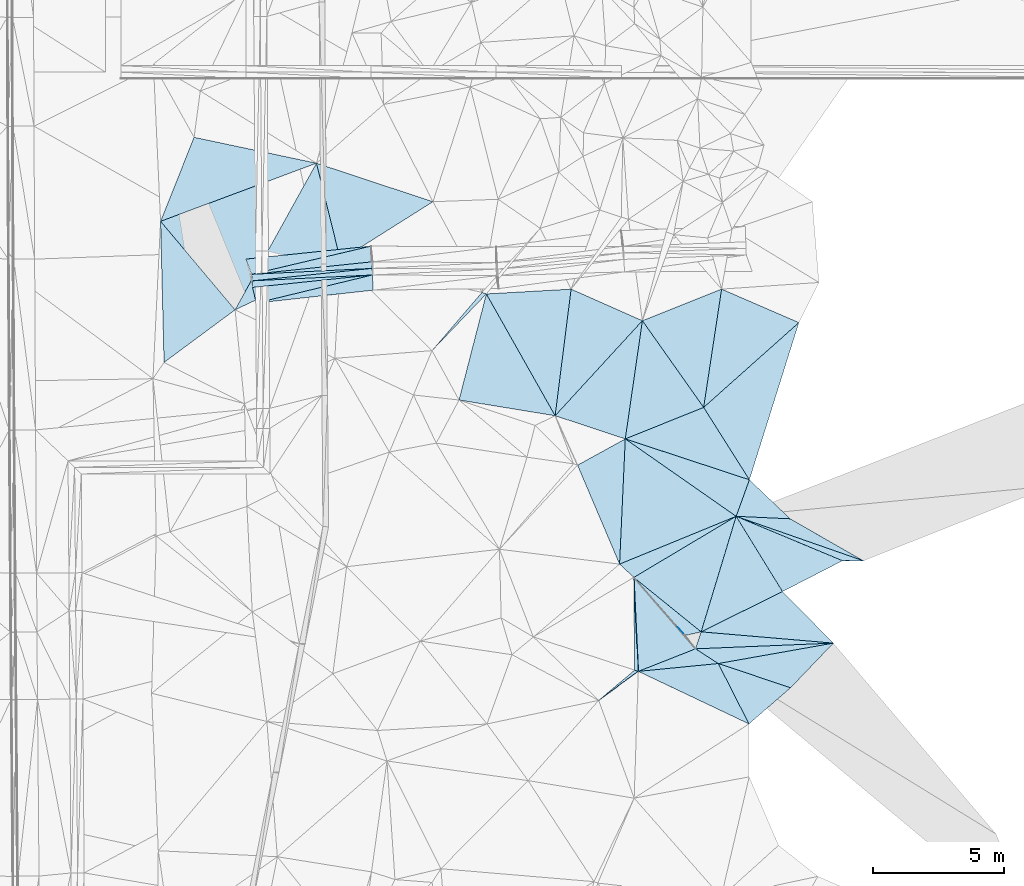
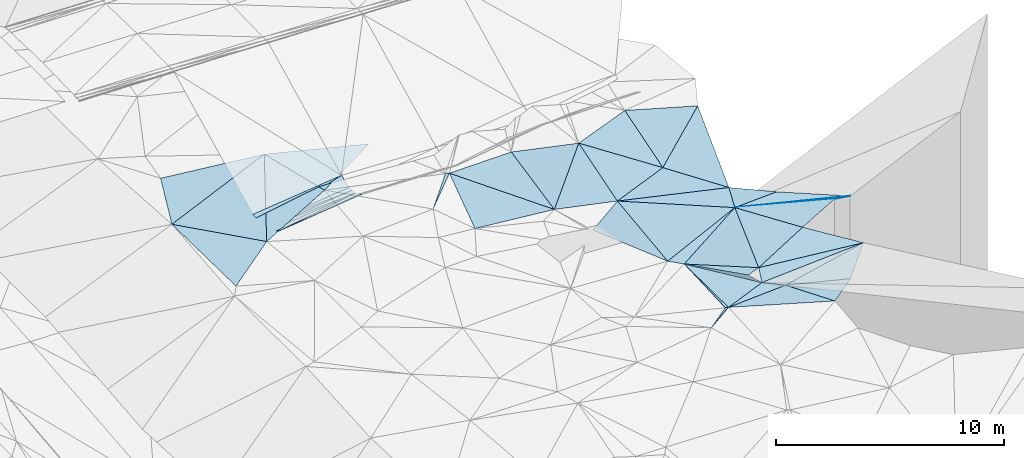
# One storey, part 100 of 275: 45 plates.
"""IFC2X3 building model written with IfcOpenShell, lengths in millimetres."""

from ifc_helpers import new_model, si_unit, frame, origin_with_axes, place, context, subcontext, project, spatial, polyline, outline, extrude, material, type_object, element, save


model = new_model("IFC2X3")

# Units and contexts
model_context = context("Model", 3, precision=1e-05, world=origin_with_axes())
body_context = subcontext(model_context, "Body", "Model", "MODEL_VIEW")
ifc_project = project(units=[si_unit("LENGTHUNIT", "METRE", prefix="MILLI"), si_unit("AREAUNIT", "SQUARE_METRE"), si_unit("VOLUMEUNIT", "CUBIC_METRE"), si_unit("MASSUNIT", "GRAM", prefix="KILO"), si_unit("TIMEUNIT", "SECOND"), si_unit("PLANEANGLEUNIT", "RADIAN"), si_unit("SOLIDANGLEUNIT", "STERADIAN"), si_unit("THERMODYNAMICTEMPERATUREUNIT", "DEGREE_CELSIUS"), si_unit("LUMINOUSINTENSITYUNIT", "LUMEN")], contexts=[model_context])

# Site, building, storey
site_placement = place(None, origin_with_axes())
site = spatial("IfcSite", under=ifc_project, at=site_placement, CompositionType="ELEMENT")
building_placement = place(site_placement, origin_with_axes())
building = spatial("IfcBuilding", under=site, at=building_placement, Name="Undefined", CompositionType="ELEMENT")
storey_placement = place(building_placement, origin_with_axes())
storey = spatial("IfcBuildingStorey", under=building, at=storey_placement, Name="Undefined", CompositionType="ELEMENT", Elevation=0.0)

# Plates
ifc_material = material()
plate_type_1 = type_object("IfcPlateType", PredefinedType="NOTDEFINED")
plate_1_placement = place(storey_placement, frame((-43648.8999455357, 52557.2817556051, 44878.2281642604), z_axis=(0.0255180972066615, 0.00110138363461027, -0.999673753616169), x_axis=(-0.99431762158297, -0.103355985983788, -0.0254952460451794)))
element("IfcPlate", 1, at=plate_1_placement, inside=storey, type_object=plate_type_1, material=ifc_material, Name="00_PR", context=body_context, shape_type="SweptSolid", body=[
    extrude(outline(polyline([(0.0, 0.0), (4599.837890625, -1.06265360955149e-08), (4584.71435546875, 250.000427246094), (0.0, 0.0)])), frame((-8.85201319254618e-08, 2.18876761149539e-07, -0.5000001331573), z_axis=(0.0, 0.0, 1.0), x_axis=(1.0, 0.0, 0.0)), (0.0, 0.0, 1.0), 1.0),
])
plate_2_placement = place(storey_placement, frame((-48233.3997002536, 52332.0848510419, 44760.9541646184), z_axis=(0.0255797537881398, -0.000154311443239196, -0.99967277265319), x_axis=(0.994319372064054, 0.103356003034222, 0.0254268160597377)))
element("IfcPlate", 2, at=plate_2_placement, inside=storey, type_object=plate_type_1, material=ifc_material, Name="00_PR", context=body_context, shape_type="SweptSolid", body=[
    extrude(outline(polyline([(0.0, 0.0), (4598.4130859375, -4.36557456851006e-09), (4584.71435546875, 250.000350952148), (0.0, 0.0)])), frame((-8.85201319254618e-08, 2.18876761149539e-07, -0.5000001331573), z_axis=(0.0, 0.0, 1.0), x_axis=(1.0, 0.0, 0.0)), (0.0, 0.0, 1.0), 1.0),
])
plate_3_placement = place(storey_placement, frame((-43661.1087510573, 52807.3598243362, 44877.877163002), z_axis=(0.0252905547313943, 0.00262884315740283, -0.999676686246625), x_axis=(-0.994319372064342, -0.103356003031297, -0.0254268160603611)))
element("IfcPlate", 3, at=plate_3_placement, inside=storey, type_object=plate_type_1, material=ifc_material, Name="00_PR", context=body_context, shape_type="SweptSolid", body=[
    extrude(outline(polyline([(0.0, 0.0), (4598.4130859375, -4.36557456851006e-09), (4598.41259765625, 249.999389648438), (0.0, 0.0)])), frame((-8.85201319254618e-08, 2.18876761149539e-07, -0.5000001331573), z_axis=(0.0, 0.0, 1.0), x_axis=(1.0, 0.0, 0.0)), (0.0, 0.0, 1.0), 1.0),
])
plate_4_placement = place(storey_placement, frame((-48259.246936965, 52580.7458929867, 44760.9541626138), z_axis=(0.0252901174471927, 0.00263770219602818, -0.999676673973456), x_axis=(0.994319372064054, 0.103356003034222, 0.0254268160597377)))
element("IfcPlate", 4, at=plate_4_placement, inside=storey, type_object=plate_type_1, material=ifc_material, Name="00_PR", context=body_context, shape_type="SweptSolid", body=[
    extrude(outline(polyline([(0.0, 0.0), (4612.1298828125, -3.50701157003641e-09), (4598.41259765625, 250.000640869141), (0.0, 0.0)])), frame((-8.85201319254618e-08, 2.18876761149539e-07, -0.5000001331573), z_axis=(0.0, 0.0, 1.0), x_axis=(1.0, 0.0, 0.0)), (0.0, 0.0, 1.0), 1.0),
])
plate_type_2 = type_object("IfcPlateType", PredefinedType="NOTDEFINED")
plate_5_placement = place(storey_placement, frame((-45784.190844131, 56819.42393406, 45119.5004673724), z_axis=(0.042328376030952, 0.0104502628297619, -0.999049098187557), x_axis=(0.239688747520526, -0.970849784627901, 1.78744209088406e-11)))
element("IfcPlate", 5, at=plate_5_placement, inside=storey, type_object=plate_type_2, material=ifc_material, Name="00", context=body_context, shape_type="SweptSolid", body=[
    extrude(outline(polyline([(0.0, 0.0), (3807.63696289063, -1.39334588311613e-09), (4685.5830078125, 4357.86767578125), (0.0, 0.0)])), frame((-8.85201319254618e-08, 2.18876761149539e-07, -0.5000001331573), z_axis=(0.0, 0.0, 1.0), x_axis=(1.0, 0.0, 0.0)), (0.0, 0.0, 1.0), 1.0),
])
plate_type_3 = type_object("IfcPlateType", PredefinedType="NOTDEFINED")
plate_6_placement = place(storey_placement, frame((-39304.8952043887, 51833.5359788315, 44859.5004166863), z_axis=(0.0315801572810692, 0.0264274692560809, -0.999151781530125), x_axis=(0.491544439626039, -0.870820222904116, -0.00749688294893047)))
element("IfcPlate", 6, at=plate_6_placement, inside=storey, type_object=plate_type_3, material=ifc_material, Name="00", context=body_context, shape_type="SweptSolid", body=[
    extrude(outline(polyline([(0.0, 0.0), (5335.55078125, -5.07861841470003e-09), (3012.92236328125, 2899.72387695313), (0.0, 0.0)])), frame((-8.85201319254618e-08, 2.18876761149539e-07, -0.5000001331573), z_axis=(0.0, 0.0, 1.0), x_axis=(1.0, 0.0, 0.0)), (0.0, 0.0, 1.0), 1.0),
])
plate_type_4 = type_object("IfcPlateType", PredefinedType="NOTDEFINED")
plate_7_placement = place(storey_placement, frame((-36072.6592416303, 52016.0193810737, 44749.5017772848), z_axis=(0.0807210893255399, -0.024634183047499, -0.996432267022541), x_axis=(0.911205882429908, -0.403340228551178, 0.0837884231706068)))
element("IfcPlate", 7, at=plate_7_placement, inside=storey, type_object=plate_type_4, material=ifc_material, Name="00", context=body_context, shape_type="SweptSolid", body=[
    extrude(outline(polyline([(0.0, 0.0), (2983.70581054688, -1.00189936347306e-08), (1398.09362792969, 4662.53515625), (0.0, 0.0)])), frame((-8.85201319254618e-08, 2.18876761149539e-07, -0.5000001331573), z_axis=(0.0, 0.0, 1.0), x_axis=(1.0, 0.0, 0.0)), (0.0, 0.0, 1.0), 1.0),
])
plate_type_5 = type_object("IfcPlateType", PredefinedType="NOTDEFINED")
plate_8_placement = place(storey_placement, frame((-36682.2674930001, 47187.2122828839, 44819.5002990938), z_axis=(-0.0334318596501539, -0.0102672718098726, -0.999388259831941), x_axis=(-0.491544439629632, 0.8708202229022, 0.00749688293586785)))
element("IfcPlate", 8, at=plate_8_placement, inside=storey, type_object=plate_type_5, material=ifc_material, Name="00", context=body_context, shape_type="SweptSolid", body=[
    extrude(outline(polyline([(0.0, 0.0), (5335.55078125, -5.07861841470003e-09), (3904.8828125, 2906.1640625), (0.0, 0.0)])), frame((-8.85201319254618e-08, 2.18876761149539e-07, -0.5000001331573), z_axis=(0.0, 0.0, 1.0), x_axis=(1.0, 0.0, 0.0)), (0.0, 0.0, 1.0), 1.0),
])
plate_type_6 = type_object("IfcPlateType", PredefinedType="NOTDEFINED")
plate_9_placement = place(storey_placement, frame((-31113.9478580462, 38944.9055605561, 44759.5072704661), z_axis=(0.141047091180109, 0.0950192787353727, -0.985432420178187), x_axis=(-0.963075260495538, -0.217405983537428, -0.15881020415444)))
element("IfcPlate", 9, at=plate_9_placement, inside=storey, type_object=plate_type_6, material=ifc_material, Name="00", context=body_context, shape_type="SweptSolid", body=[
    extrude(outline(polyline([(0.0, 0.0), (629.682434082031, -2.18278728425503e-10), (2046.12658691406, 2595.818359375), (0.0, 0.0)])), frame((-8.85201319254618e-08, 2.18876761149539e-07, -0.5000001331573), z_axis=(0.0, 0.0, 1.0), x_axis=(1.0, 0.0, 0.0)), (0.0, 0.0, 1.0), 1.0),
])
plate_type_7 = type_object("IfcPlateType", PredefinedType="NOTDEFINED")
plate_10_placement = place(storey_placement, frame((-48082.9435581768, 51483.8467861564, 45064.2681711267), z_axis=(0.0698065277647561, -0.443281968600509, -0.893659971686707), x_axis=(0.971129294650725, 0.235050272959115, -0.0407340429251781)))
element("IfcPlate", 10, at=plate_10_placement, inside=storey, type_object=plate_type_7, material=ifc_material, Name="00_PR", context=body_context, shape_type="SweptSolid", body=[
    extrude(outline(polyline([(0.0, 0.0), (4565.88623046875, -2.25554686039686e-09), (4445.12744140625, 638.348693847656), (0.0, 0.0)])), frame((-8.85201319254618e-08, 2.18876761149539e-07, -0.5000001331573), z_axis=(0.0, 0.0, 1.0), x_axis=(1.0, 0.0, 0.0)), (0.0, 0.0, 1.0), 1.0),
])
plate_type_8 = type_object("IfcPlateType", PredefinedType="NOTDEFINED")
plate_11_placement = place(storey_placement, frame((-48222.5782976455, 52081.6411384911, 44761.0059614834), z_axis=(0.0685639128320378, -0.438567238991549, -0.896079107412114), x_axis=(0.994317621581248, 0.103355986000169, 0.025495246045956)))
element("IfcPlate", 11, at=plate_11_placement, inside=storey, type_object=plate_type_8, material=ifc_material, Name="00_PR", context=body_context, shape_type="SweptSolid", body=[
    extrude(outline(polyline([(0.0, 0.0), (4599.837890625, -1.06265360955149e-08), (84.786994934082, 679.4345703125), (0.0, 0.0)])), frame((-8.85201319254618e-08, 2.18876761149539e-07, -0.5000001331573), z_axis=(0.0, 0.0, 1.0), x_axis=(1.0, 0.0, 0.0)), (0.0, 0.0, 1.0), 1.0),
])
plate_type_9 = type_object("IfcPlateType", PredefinedType="NOTDEFINED")
plate_12_placement = place(storey_placement, frame((-43673.3413795637, 53057.6606631243, 44878.2809048166), z_axis=(-0.0236035524691922, 0.447059240993688, -0.894192880397167), x_axis=(-0.994319372064342, -0.103356003031297, -0.0254268160603611)))
element("IfcPlate", 12, at=plate_12_placement, inside=storey, type_object=plate_type_9, material=ifc_material, Name="00_PR", context=body_context, shape_type="SweptSolid", body=[
    extrude(outline(polyline([(0.0, 0.0), (4612.1298828125, -3.50701157003641e-09), (-40.548267364502, 670.779235839844), (0.0, 0.0)])), frame((-8.85201319254618e-08, 2.18876761149539e-07, -0.5000001331573), z_axis=(0.0, 0.0, 1.0), x_axis=(1.0, 0.0, 0.0)), (0.0, 0.0, 1.0), 1.0),
])
plate_type_10 = type_object("IfcPlateType", PredefinedType="NOTDEFINED")
plate_13_placement = place(storey_placement, frame((-48474.8275715571, 53161.797261578, 45061.0080289067), z_axis=(-0.0248522998880552, 0.451468694546112, -0.891940794579496), x_axis=(0.994339666083625, 0.103358287018405, 0.0246108300820255)))
element("IfcPlate", 13, at=plate_13_placement, inside=storey, type_object=plate_type_10, material=ifc_material, Name="00_PR", context=body_context, shape_type="SweptSolid", body=[
    extrude(outline(polyline([(0.0, 0.0), (4799.3505859375, 1.07538653537631e-08), (146.918914794922, 672.487182617188), (0.0, 0.0)])), frame((-8.85201319254618e-08, 2.18876761149539e-07, -0.5000001331573), z_axis=(0.0, 0.0, 1.0), x_axis=(1.0, 0.0, 0.0)), (0.0, 0.0, 1.0), 1.0),
])
plate_type_11 = type_object("IfcPlateType", PredefinedType="NOTDEFINED")
plate_14_placement = place(storey_placement, frame((-34223.9627596515, 41527.9390451891, 44629.505718644), z_axis=(0.14462819527124, 0.0430907338323326, -0.988547355360569), x_axis=(-0.390860293663412, 0.920291739064717, -0.0170688560422473)))
element("IfcPlate", 14, at=plate_14_placement, inside=storey, type_object=plate_type_11, material=ifc_material, Name="00", context=body_context, shape_type="SweptSolid", body=[
    extrude(outline(polyline([(0.0, 0.0), (4101.03662109375, -5.41876943316311e-09), (4305.98486328125, 2090.78833007813), (0.0, 0.0)])), frame((-8.85201319254618e-08, 2.18876761149539e-07, -0.5000001331573), z_axis=(0.0, 0.0, 1.0), x_axis=(1.0, 0.0, 0.0)), (0.0, 0.0, 1.0), 1.0),
])
plate_type_12 = type_object("IfcPlateType", PredefinedType="NOTDEFINED")
plate_15_placement = place(storey_placement, frame((-26069.3905646251, 38515.1299065926, 44588.553759336), z_axis=(0.00818748525516225, 0.451017159030937, -0.892477723724721), x_axis=(-0.998697273279116, -0.0412653025049259, -0.0300155152219015)))
element("IfcPlate", 15, at=plate_15_placement, inside=storey, type_object=plate_type_12, material=ifc_material, Name="00", context=body_context, shape_type="SweptSolid", body=[
    extrude(outline(polyline([(0.0, 0.0), (5263.9443359375, 1.59343471750617e-09), (5015.17724609375, 714.372436523438), (0.0, 0.0)])), frame((-8.85201319254618e-08, 2.18876761149539e-07, -0.5000001331573), z_axis=(0.0, 0.0, 1.0), x_axis=(1.0, 0.0, 0.0)), (0.0, 0.0, 1.0), 1.0),
])
plate_type_13 = type_object("IfcPlateType", PredefinedType="NOTDEFINED")
plate_16_placement = place(storey_placement, frame((-33679.8573564303, 41021.7118447759, 44592.5009604908), z_axis=(0.0623125531495607, -0.0032687167465236, -0.998051331951826), x_axis=(0.857456106421156, 0.511937279405322, 0.0518579551867378)))
element("IfcPlate", 16, at=plate_16_placement, inside=storey, type_object=plate_type_13, material=ifc_material, Name="00", context=body_context, shape_type="SweptSolid", body=[
    extrude(outline(polyline([(0.0, 0.0), (4550.89306640625, 3.56521923094988e-09), (1145.5615234375, 3100.41870117188), (0.0, 0.0)])), frame((-8.85201319254618e-08, 2.18876761149539e-07, -0.5000001331573), z_axis=(0.0, 0.0, 1.0), x_axis=(1.0, 0.0, 0.0)), (0.0, 0.0, 1.0), 1.0),
])
plate_type_14 = type_object("IfcPlateType", PredefinedType="NOTDEFINED")
plate_17_placement = place(storey_placement, frame((-51597.7518324005, 49219.7921765297, 44709.5012111229), z_axis=(0.0674026633223797, 0.0183408638626135, -0.997557263363775), x_axis=(-0.0246074145858598, 0.999557444501428, 0.0167149720063911)))
element("IfcPlate", 17, at=plate_17_placement, inside=storey, type_object=plate_type_14, material=ifc_material, Name="00", context=body_context, shape_type="SweptSolid", body=[
    extrude(outline(polyline([(0.0, 0.0), (5384.39404296875, 8.73114913702011e-11), (1943.20654296875, 2764.787109375), (0.0, 0.0)])), frame((-8.85201319254618e-08, 2.18876761149539e-07, -0.5000001331573), z_axis=(0.0, 0.0, 1.0), x_axis=(1.0, 0.0, 0.0)), (0.0, 0.0, 1.0), 1.0),
])
plate_type_15 = type_object("IfcPlateType", PredefinedType="NOTDEFINED")
plate_18_placement = place(storey_placement, frame((-41377.4282599691, 49670.817961365, 44979.500478981), z_axis=(-0.0142652871125342, -0.0417620600686916, -0.99902574137127), x_axis=(0.650705597418821, 0.758223093234716, -0.0409873928592122)))
element("IfcPlate", 18, at=plate_18_placement, inside=storey, type_object=plate_type_15, material=ifc_material, Name="00", context=body_context, shape_type="SweptSolid", body=[
    extrude(outline(polyline([(0.0, 0.0), (2927.7294921875, 5.77711034566164e-09), (2993.30932617188, 164.314590454102), (0.0, 0.0)])), frame((-8.85201319254618e-08, 2.18876761149539e-07, -0.5000001331573), z_axis=(0.0, 0.0, 1.0), x_axis=(1.0, 0.0, 0.0)), (0.0, 0.0, 1.0), 1.0),
])
plate_type_16 = type_object("IfcPlateType", PredefinedType="NOTDEFINED")
plate_19_placement = place(storey_placement, frame((-26069.4056651651, 38514.9718453244, 44588.5046807358), z_axis=(-0.0220822810884589, 0.134894036849577, -0.990613936750516), x_axis=(-0.995819756501602, 0.0848737903911823, 0.033755773813146)))
element("IfcPlate", 19, at=plate_19_placement, inside=storey, type_object=plate_type_16, material=ifc_material, Name="00", context=body_context, shape_type="SweptSolid", body=[
    extrude(outline(polyline([(0.0, 0.0), (5065.7998046875, -6.81757228448987e-09), (2109.99633789063, 1810.22790527344), (0.0, 0.0)])), frame((-8.85201319254618e-08, 2.18876761149539e-07, -0.5000001331573), z_axis=(0.0, 0.0, 1.0), x_axis=(1.0, 0.0, 0.0)), (0.0, 0.0, 1.0), 1.0),
])
plate_type_17 = type_object("IfcPlateType", PredefinedType="NOTDEFINED")
plate_20_placement = place(storey_placement, frame((-33509.1279737156, 37437.7357755065, 44389.5009098967), z_axis=(0.0191368967585777, 0.0574483201086814, -0.998165051331263), x_axis=(-0.948745425214858, 0.316041323459256, -1.17439657999727e-10)))
element("IfcPlate", 20, at=plate_20_placement, inside=storey, type_object=plate_type_17, material=ifc_material, Name="00", context=body_context, shape_type="SweptSolid", body=[
    extrude(outline(polyline([(0.0, 0.0), (148.660690307617, 2.47382558882236e-10), (1294.693359375, 3352.4970703125), (0.0, 0.0)])), frame((-8.85201319254618e-08, 2.18876761149539e-07, -0.5000001331573), z_axis=(0.0, 0.0, 1.0), x_axis=(1.0, 0.0, 0.0)), (0.0, 0.0, 1.0), 1.0),
])
plate_type_18 = type_object("IfcPlateType", PredefinedType="NOTDEFINED")
plate_21_placement = place(storey_placement, frame((-31017.0103705482, 47505.0780924867, 44879.5002210683), z_axis=(-0.0216061066595711, 0.0209987115804917, -0.999546012080972), x_axis=(-0.576794692404829, 0.816352039534228, 0.0296180749192969)))
element("IfcPlate", 21, at=plate_21_placement, inside=storey, type_object=plate_type_18, material=ifc_material, Name="00", context=body_context, shape_type="SweptSolid", body=[
    extrude(outline(polyline([(0.0, 0.0), (4051.57983398438, -2.31011654250324e-09), (3291.08642578125, 3162.30126953125), (0.0, 0.0)])), frame((-8.85201319254618e-08, 2.18876761149539e-07, -0.5000001331573), z_axis=(0.0, 0.0, 1.0), x_axis=(1.0, 0.0, 0.0)), (0.0, 0.0, 1.0), 1.0),
])
plate_type_19 = type_object("IfcPlateType", PredefinedType="NOTDEFINED")
plate_22_placement = place(storey_placement, frame((-30459.4504583157, 37736.428071483, 44329.5110452874), z_axis=(0.0207935485197935, 0.208057991256092, -0.97789544462301), x_axis=(-0.835431484716806, 0.540909437745007, 0.0973201649312877)))
element("IfcPlate", 22, at=plate_22_placement, inside=storey, type_object=plate_type_19, material=ifc_material, Name="00", context=body_context, shape_type="SweptSolid", body=[
    extrude(outline(polyline([(0.0, 0.0), (1037.81164550781, 1.42608769237995e-09), (-3221.25219726563, 3093.45825195313), (0.0, 0.0)])), frame((-8.85201319254618e-08, 2.18876761149539e-07, -0.5000001331573), z_axis=(0.0, 0.0, 1.0), x_axis=(1.0, 0.0, 0.0)), (0.0, 0.0, 1.0), 1.0),
])
plate_type_20 = type_object("IfcPlateType", PredefinedType="NOTDEFINED")
plate_23_placement = place(storey_placement, frame((-24923.3503266508, 41655.614728403, 44778.5265508137), z_axis=(0.0973168220810569, 0.306451990481336, -0.946898417820027), x_axis=(-0.943994340419225, 0.329818348561339, 0.00972328178875151)))
element("IfcPlate", 23, at=plate_23_placement, inside=storey, type_object=plate_type_20, material=ifc_material, Name="00", context=body_context, shape_type="SweptSolid", body=[
    extrude(outline(polyline([(0.0, 0.0), (5142.29638671875, 1.11322151497006e-08), (3167.74780273438, 622.924499511719), (0.0, 0.0)])), frame((-8.85201319254618e-08, 2.18876761149539e-07, -0.5000001331573), z_axis=(0.0, 0.0, 1.0), x_axis=(1.0, 0.0, 0.0)), (0.0, 0.0, 1.0), 1.0),
])
plate_type_21 = type_object("IfcPlateType", PredefinedType="NOTDEFINED")
plate_24_placement = place(storey_placement, frame((-26069.3792950916, 38514.9822552424, 44588.5063292803), z_axis=(0.0306351748514603, 0.155703492347904, -0.987328673002302), x_axis=(-0.685696902516036, -0.715427756403064, -0.134100273109315)))
element("IfcPlate", 24, at=plate_24_placement, inside=storey, type_object=plate_type_21, material=ifc_material, Name="00", context=body_context, shape_type="SweptSolid", body=[
    extrude(outline(polyline([(0.0, 0.0), (2378.81689453125, -4.14729584008455e-10), (3602.0048828125, 2640.36206054688), (0.0, 0.0)])), frame((-8.85201319254618e-08, 2.18876761149539e-07, -0.5000001331573), z_axis=(0.0, 0.0, 1.0), x_axis=(1.0, 0.0, 0.0)), (0.0, 0.0, 1.0), 1.0),
])
plate_type_22 = type_object("IfcPlateType", PredefinedType="NOTDEFINED")
plate_25_placement = place(storey_placement, frame((-33509.1535950924, 37437.7714218002, 44389.5044130526), z_axis=(-0.0321062555033456, 0.128740816779132, -0.991158408354889), x_axis=(0.9302452787883, 0.366521998574027, 0.017474148144623)))
element("IfcPlate", 25, at=plate_25_placement, inside=storey, type_object=plate_type_22, material=ifc_material, Name="00", context=body_context, shape_type="SweptSolid", body=[
    extrude(outline(polyline([(0.0, 0.0), (2346.3232421875, -6.55563781037927e-09), (2945.3486328125, 847.479614257813), (0.0, 0.0)])), frame((-8.85201319254618e-08, 2.18876761149539e-07, -0.5000001331573), z_axis=(0.0, 0.0, 1.0), x_axis=(1.0, 0.0, 0.0)), (0.0, 0.0, 1.0), 1.0),
])
plate_type_23 = type_object("IfcPlateType", PredefinedType="NOTDEFINED")
plate_26_placement = place(storey_placement, frame((-29777.7627780694, 43351.3124191082, 44828.5353351232), z_axis=(-0.130306677990906, -0.34556257541638, -0.929304404456674), x_axis=(0.943994340449366, -0.329818348473931, -0.00972328182736621)))
element("IfcPlate", 26, at=plate_26_placement, inside=storey, type_object=plate_type_23, material=ifc_material, Name="00", context=body_context, shape_type="SweptSolid", body=[
    extrude(outline(polyline([(0.0, 0.0), (5142.29638671875, 1.11322151497006e-08), (4388.353515625, 280.804290771484), (0.0, 0.0)])), frame((-8.85201319254618e-08, 2.18876761149539e-07, -0.5000001331573), z_axis=(0.0, 0.0, 1.0), x_axis=(1.0, 0.0, 0.0)), (0.0, 0.0, 1.0), 1.0),
])
plate_type_24 = type_object("IfcPlateType", PredefinedType="NOTDEFINED")
plate_27_placement = place(storey_placement, frame((-27717.2928275366, 43256.4672055309, 45009.5019272505), z_axis=(0.0877221662888086, 0.00462028364222227, -0.996134265307977), x_axis=(-0.995113901804775, 0.0458929443992536, -0.0874194491474491)))
element("IfcPlate", 27, at=plate_27_placement, inside=storey, type_object=plate_type_24, material=ifc_material, Name="00", context=body_context, shape_type="SweptSolid", body=[
    extrude(outline(polyline([(0.0, 0.0), (2070.4775390625, -2.4156179279089e-09), (1626.70202636719, 1415.35876464844), (0.0, 0.0)])), frame((-8.85201319254618e-08, 2.18876761149539e-07, -0.5000001331573), z_axis=(0.0, 0.0, 1.0), x_axis=(1.0, 0.0, 0.0)), (0.0, 0.0, 1.0), 1.0),
])
plate_type_25 = type_object("IfcPlateType", PredefinedType="NOTDEFINED")
plate_28_placement = place(storey_placement, frame((-29271.9519934362, 44744.9873894707, 44879.5002893212), z_axis=(0.0126423161658083, 0.031988911010459, -0.999408265632384), x_axis=(-0.340955649417695, -0.939450407153577, -0.034382810082013)))
element("IfcPlate", 28, at=plate_28_placement, inside=storey, type_object=plate_type_25, material=ifc_material, Name="00", context=body_context, shape_type="SweptSolid", body=[
    extrude(outline(polyline([(0.0, 0.0), (1483.29931640625, 6.47560227662325e-10), (150.279846191406, 4982.2802734375), (0.0, 0.0)])), frame((-8.85201319254618e-08, 2.18876761149539e-07, -0.5000001331573), z_axis=(0.0, 0.0, 1.0), x_axis=(1.0, 0.0, 0.0)), (0.0, 0.0, 1.0), 1.0),
])
plate_type_26 = type_object("IfcPlateType", PredefinedType="NOTDEFINED")
plate_29_placement = place(storey_placement, frame((-31113.9964272117, 38944.8592144661, 44759.5004703229), z_axis=(0.0439090967716739, 0.00232754618664031, -0.999032819155329), x_axis=(0.29016957737295, 0.956857949167388, 0.0149827061101567)))
element("IfcPlate", 29, at=plate_29_placement, inside=storey, type_object=plate_type_26, material=ifc_material, Name="00", context=body_context, shape_type="SweptSolid", body=[
    extrude(outline(polyline([(0.0, 0.0), (4605.3095703125, -1.42463250085711e-08), (2372.69604492188, 2526.66064453125), (0.0, 0.0)])), frame((-8.85201319254618e-08, 2.18876761149539e-07, -0.5000001331573), z_axis=(0.0, 0.0, 1.0), x_axis=(1.0, 0.0, 0.0)), (0.0, 0.0, 1.0), 1.0),
])
plate_type_27 = type_object("IfcPlateType", PredefinedType="NOTDEFINED")
plate_30_placement = place(storey_placement, frame((-28010.1259821064, 40481.0675527499, 44899.5001058862), z_axis=(0.00633412081311151, -0.0208288151998633, -0.999762991598956), x_axis=(-0.524231596593874, 0.851315345743247, -0.0210574270672891)))
element("IfcPlate", 30, at=plate_30_placement, inside=storey, type_object=plate_type_27, material=ifc_material, Name="00", context=body_context, shape_type="SweptSolid", body=[
    extrude(outline(polyline([(0.0, 0.0), (3371.73193359375, -7.31597538106143e-09), (-198.773208618164, 2566.70776367188), (0.0, 0.0)])), frame((-8.85201319254618e-08, 2.18876761149539e-07, -0.5000001331573), z_axis=(0.0, 0.0, 1.0), x_axis=(1.0, 0.0, 0.0)), (0.0, 0.0, 1.0), 1.0),
])
plate_type_28 = type_object("IfcPlateType", PredefinedType="NOTDEFINED")
plate_31_placement = place(storey_placement, frame((-30459.4673751593, 37736.2904039831, 44329.5011684257), z_axis=(-0.0130403544562653, -0.0672770893462946, -0.997649107855435), x_axis=(0.452642576681095, -0.890049101035985, 0.0541044870646945)))
element("IfcPlate", 31, at=plate_31_placement, inside=storey, type_object=plate_type_28, material=ifc_material, Name="00", context=body_context, shape_type="SweptSolid", body=[
    extrude(outline(polyline([(0.0, 0.0), (2587.58569335938, -5.51699486095458e-09), (-1111.38342285156, 2856.24340820313), (0.0, 0.0)])), frame((-8.85201319254618e-08, 2.18876761149539e-07, -0.5000001331573), z_axis=(0.0, 0.0, 1.0), x_axis=(1.0, 0.0, 0.0)), (0.0, 0.0, 1.0), 1.0),
])
plate_type_29 = type_object("IfcPlateType", PredefinedType="NOTDEFINED")
plate_32_placement = place(storey_placement, frame((-33679.8902330943, 41021.7416774594, 44592.5007910599), z_axis=(-0.00346161971792915, 0.0563851534843127, -0.998403090768192), x_axis=(0.653092227483367, -0.755942759596964, -0.0449564969024457)))
element("IfcPlate", 32, at=plate_32_placement, inside=storey, type_object=plate_type_29, material=ifc_material, Name="00", context=body_context, shape_type="SweptSolid", body=[
    extrude(outline(polyline([(0.0, 0.0), (3603.48364257813, -3.83352016797289e-10), (2829.94604492188, 2215.14624023438), (0.0, 0.0)])), frame((-8.85201319254618e-08, 2.18876761149539e-07, -0.5000001331573), z_axis=(0.0, 0.0, 1.0), x_axis=(1.0, 0.0, 0.0)), (0.0, 0.0, 1.0), 1.0),
])
plate_type_30 = type_object("IfcPlateType", PredefinedType="NOTDEFINED")
plate_33_placement = place(storey_placement, frame((-35021.1425610373, 36331.8813225131, 44499.5012847698), z_axis=(-0.0227082085142451, -0.068169276757749, -0.997415303157315), x_axis=(0.763942657929561, 0.642366277751107, -0.0612958449138699)))
element("IfcPlate", 33, at=plate_33_placement, inside=storey, type_object=plate_type_30, material=ifc_material, Name="00", context=body_context, shape_type="SweptSolid", body=[
    extrude(outline(polyline([(0.0, 0.0), (1794.5751953125, 1.86264514923096e-09), (1872.14221191406, 126.820121765137), (0.0, 0.0)])), frame((-8.85201319254618e-08, 2.18876761149539e-07, -0.5000001331573), z_axis=(0.0, 0.0, 1.0), x_axis=(1.0, 0.0, 0.0)), (0.0, 0.0, 1.0), 1.0),
])
plate_type_31 = type_object("IfcPlateType", PredefinedType="NOTDEFINED")
plate_34_placement = place(storey_placement, frame((-30332.9328592688, 52016.9555266038, 44959.5000717722), z_axis=(0.00402347092216721, 0.0171182134528672, -0.999845377270866), x_axis=(0.917608374768125, -0.397473499251777, -0.00311254685872315)))
element("IfcPlate", 34, at=plate_34_placement, inside=storey, type_object=plate_type_31, material=ifc_material, Name="00", context=body_context, shape_type="SweptSolid", body=[
    extrude(outline(polyline([(0.0, 0.0), (3212.80249023438, -8.65838956087828e-10), (1165.89794921875, 4412.71826171875), (0.0, 0.0)])), frame((-8.85201319254618e-08, 2.18876761149539e-07, -0.5000001331573), z_axis=(0.0, 0.0, 1.0), x_axis=(1.0, 0.0, 0.0)), (0.0, 0.0, 1.0), 1.0),
])
plate_type_32 = type_object("IfcPlateType", PredefinedType="NOTDEFINED")
plate_35_placement = place(storey_placement, frame((-51730.2547685463, 54601.7945391656, 44799.5007089888), z_axis=(0.053576049036544, 0.000438967004925107, -0.998563675624946), x_axis=(0.370463182310871, 0.928625629885694, 0.0202847250782401)))
element("IfcPlate", 35, at=plate_35_placement, inside=storey, type_object=plate_type_32, material=ifc_material, Name="00", context=body_context, shape_type="SweptSolid", body=[
    extrude(outline(polyline([(0.0, 0.0), (3450.87255859375, 1.78988557308912e-09), (4268.6337890625, 4706.884765625), (0.0, 0.0)])), frame((-8.85201319254618e-08, 2.18876761149539e-07, -0.5000001331573), z_axis=(0.0, 0.0, 1.0), x_axis=(1.0, 0.0, 0.0)), (0.0, 0.0, 1.0), 1.0),
])
plate_type_33 = type_object("IfcPlateType", PredefinedType="NOTDEFINED")
plate_36_placement = place(storey_placement, frame((-33353.9337446599, 50812.5981810358, 44999.5002392506), z_axis=(-0.00874614889035957, 0.030083594529916, -0.999509120628595), x_axis=(0.576794692401653, -0.816352039536737, -0.0296180749120022)))
element("IfcPlate", 36, at=plate_36_placement, inside=storey, type_object=plate_type_33, material=ifc_material, Name="00", context=body_context, shape_type="SweptSolid", body=[
    extrude(outline(polyline([(0.0, 0.0), (4051.57983398438, -2.31011654250324e-09), (3308.28955078125, 3134.98315429688), (0.0, 0.0)])), frame((-8.85201319254618e-08, 2.18876761149539e-07, -0.5000001331573), z_axis=(0.0, 0.0, 1.0), x_axis=(1.0, 0.0, 0.0)), (0.0, 0.0, 1.0), 1.0),
])
plate_type_34 = type_object("IfcPlateType", PredefinedType="NOTDEFINED")
plate_37_placement = place(storey_placement, frame((-44871.5777212858, 53122.7717607997, 45119.5001847368), z_axis=(-0.0269457637659446, -0.00665251873816308, -0.999614760700095), x_axis=(-0.239688747518604, 0.970849784628376, -1.61966636325691e-11)))
element("IfcPlate", 37, at=plate_37_placement, inside=storey, type_object=plate_type_34, material=ifc_material, Name="00", context=body_context, shape_type="SweptSolid", body=[
    extrude(outline(polyline([(0.0, 0.0), (3807.63696289063, -1.39334588311613e-09), (1316.64331054688, 3963.27514648438), (0.0, 0.0)])), frame((-8.85201319254618e-08, 2.18876761149539e-07, -0.5000001331573), z_axis=(0.0, 0.0, 1.0), x_axis=(1.0, 0.0, 0.0)), (0.0, 0.0, 1.0), 1.0),
])
plate_type_35 = type_object("IfcPlateType", PredefinedType="NOTDEFINED")
plate_38_placement = place(storey_placement, frame((-29271.9569820934, 44744.9722368155, 44879.4999969207), z_axis=(0.00266731384675365, 0.00168638054037003, -0.999995020766362), x_axis=(-0.949846583824281, 0.312709837316141, -0.00200620115023819)))
element("IfcPlate", 38, at=plate_38_placement, inside=storey, type_object=plate_type_35, material=ifc_material, Name="00", context=body_context, shape_type="SweptSolid", body=[
    extrude(outline(polyline([(0.0, 0.0), (4984.5458984375, -5.89352566748858e-09), (2520.63061523438, 2075.98681640625), (0.0, 0.0)])), frame((-8.85201319254618e-08, 2.18876761149539e-07, -0.5000001331573), z_axis=(0.0, 0.0, 1.0), x_axis=(1.0, 0.0, 0.0)), (0.0, 0.0, 1.0), 1.0),
])
plate_type_36 = type_object("IfcPlateType", PredefinedType="NOTDEFINED")
plate_39_placement = place(storey_placement, frame((-29271.9521514198, 44744.9752914842, 44879.5000474881), z_axis=(0.0123283310620081, 0.00779445516051769, -0.99989362370303), x_axis=(-0.534391921409003, 0.845236815533253, -6.53070647964688e-11)))
element("IfcPlate", 39, at=plate_39_placement, inside=storey, type_object=plate_type_36, material=ifc_material, Name="00", context=body_context, shape_type="SweptSolid", body=[
    extrude(outline(polyline([(0.0, 0.0), (3265.47094726563, -1.60048330144491e-09), (4058.71020507813, 4799.236328125), (0.0, 0.0)])), frame((-8.85201319254618e-08, 2.18876761149539e-07, -0.5000001331573), z_axis=(0.0, 0.0, 1.0), x_axis=(1.0, 0.0, 0.0)), (0.0, 0.0, 1.0), 1.0),
])
plate_type_37 = type_object("IfcPlateType", PredefinedType="NOTDEFINED")
plate_40_placement = place(storey_placement, frame((-34006.5001325697, 46303.7125314446, 44869.500746584), z_axis=(0.0245680611672937, 0.0490589683115793, -0.998493679498615), x_axis=(0.819931143263675, -0.572406957458729, -0.00794955087808878)))
element("IfcPlate", 40, at=plate_40_placement, inside=storey, type_object=plate_type_37, material=ifc_material, Name="00", context=body_context, shape_type="SweptSolid", body=[
    extrude(outline(polyline([(0.0, 0.0), (5157.5244140625, 9.9644239526242e-09), (2557.23852539063, 4046.40966796875), (0.0, 0.0)])), frame((-8.85201319254618e-08, 2.18876761149539e-07, -0.5000001331573), z_axis=(0.0, 0.0, 1.0), x_axis=(1.0, 0.0, 0.0)), (0.0, 0.0, 1.0), 1.0),
])
plate_type_38 = type_object("IfcPlateType", PredefinedType="NOTDEFINED")
plate_41_placement = place(storey_placement, frame((-34006.4989656325, 46303.70046137, 44869.5003295521), z_axis=(0.0269020908460319, 0.0249189027964292, -0.999327436725088), x_axis=(-0.949422599458119, 0.313499558528061, -0.0177413201565997)))
element("IfcPlate", 41, at=plate_41_placement, inside=storey, type_object=plate_type_38, material=ifc_material, Name="00", context=body_context, shape_type="SweptSolid", body=[
    extrude(outline(polyline([(0.0, 0.0), (2818.27954101563, 3.9508449845016e-09), (791.653198242188, 4488.4501953125), (0.0, 0.0)])), frame((-8.85201319254618e-08, 2.18876761149539e-07, -0.5000001331573), z_axis=(0.0, 0.0, 1.0), x_axis=(1.0, 0.0, 0.0)), (0.0, 0.0, 1.0), 1.0),
])
plate_type_39 = type_object("IfcPlateType", PredefinedType="NOTDEFINED")
plate_42_placement = place(storey_placement, frame((-48887.9163335158, 51226.8853199017, 44929.5006692678), z_axis=(0.0518153312025044, 0.00517143131138955, -0.998643293549086), x_axis=(-0.643897246642087, 0.764544987848674, -0.0294499120917275)))
element("IfcPlate", 42, at=plate_42_placement, inside=storey, type_object=plate_type_39, material=ifc_material, Name="00", context=body_context, shape_type="SweptSolid", body=[
    extrude(outline(polyline([(0.0, 0.0), (4414.27490234375, -2.4087967176456e-09), (2271.66650390625, 5982.07568359375), (0.0, 0.0)])), frame((-8.85201319254618e-08, 2.18876761149539e-07, -0.5000001331573), z_axis=(0.0, 0.0, 1.0), x_axis=(1.0, 0.0, 0.0)), (0.0, 0.0, 1.0), 1.0),
])
plate_type_40 = type_object("IfcPlateType", PredefinedType="NOTDEFINED")
plate_43_placement = place(storey_placement, frame((-27700.5672496169, 36812.9896661981, 44269.5024918772), z_axis=(-0.0504701703396666, -0.0861515024314767, -0.995002854535948), x_axis=(-0.751403308705352, -0.653018757552662, 0.0946550048915901)))
element("IfcPlate", 43, at=plate_43_placement, inside=storey, type_object=plate_type_40, material=ifc_material, Name="00", context=body_context, shape_type="SweptSolid", body=[
    extrude(outline(polyline([(0.0, 0.0), (2112.93627929688, 6.12635631114244e-09), (1475.8134765625, 2507.92236328125), (0.0, 0.0)])), frame((-8.85201319254618e-08, 2.18876761149539e-07, -0.5000001331573), z_axis=(0.0, 0.0, 1.0), x_axis=(1.0, 0.0, 0.0)), (0.0, 0.0, 1.0), 1.0),
])
plate_type_41 = type_object("IfcPlateType", PredefinedType="NOTDEFINED")
plate_44_placement = place(storey_placement, frame((-31326.1114605022, 38298.0109663341, 44430.9126894003), z_axis=(0.739921383199425, 0.649635161222387, -0.174615302845466), x_axis=(-0.653092227388305, 0.75594275968144, 0.0449564968629778)))
element("IfcPlate", 44, at=plate_44_placement, inside=storey, type_object=plate_type_41, material=ifc_material, Name="00", context=body_context, shape_type="SweptSolid", body=[
    extrude(outline(polyline([(0.0, 0.0), (3603.48364257813, -3.83352016797289e-10), (653.331665039063, 202.954956054688), (0.0, 0.0)])), frame((-8.85201319254618e-08, 2.18876761149539e-07, -0.5000001331573), z_axis=(0.0, 0.0, 1.0), x_axis=(1.0, 0.0, 0.0)), (0.0, 0.0, 1.0), 1.0),
])
plate_type_42 = type_object("IfcPlateType", PredefinedType="NOTDEFINED")
plate_45_placement = place(storey_placement, frame((-29777.6925385872, 43351.5271100202, 44828.5017804059), z_axis=(0.0102199728466065, 0.0838180315923855, -0.996428667660155), x_axis=(-0.857456106420449, -0.511937279407606, -0.0518579551758783)))
element("IfcPlate", 45, at=plate_45_placement, inside=storey, type_object=plate_type_42, material=ifc_material, Name="00", context=body_context, shape_type="SweptSolid", body=[
    extrude(outline(polyline([(0.0, 0.0), (4550.89306640625, 3.56521923094988e-09), (4756.4111328125, 715.170776367188), (0.0, 0.0)])), frame((-8.85201319254618e-08, 2.18876761149539e-07, -0.5000001331573), z_axis=(0.0, 0.0, 1.0), x_axis=(1.0, 0.0, 0.0)), (0.0, 0.0, 1.0), 1.0),
])

save(model, "model.ifc")
